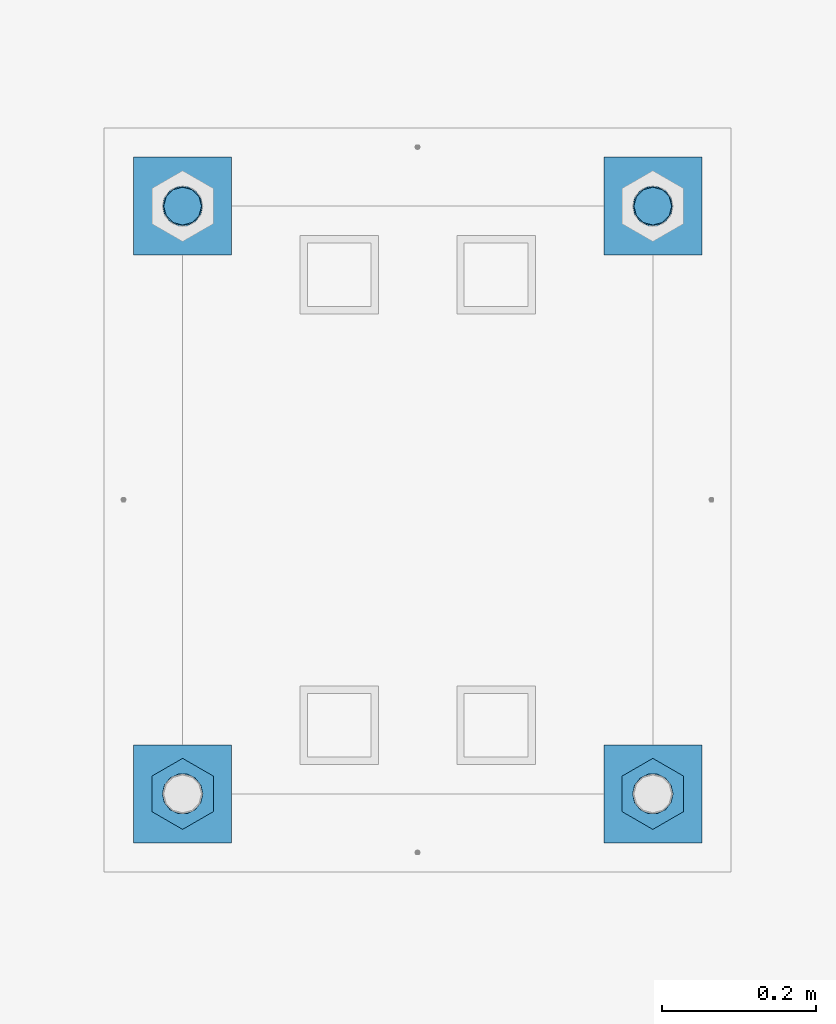
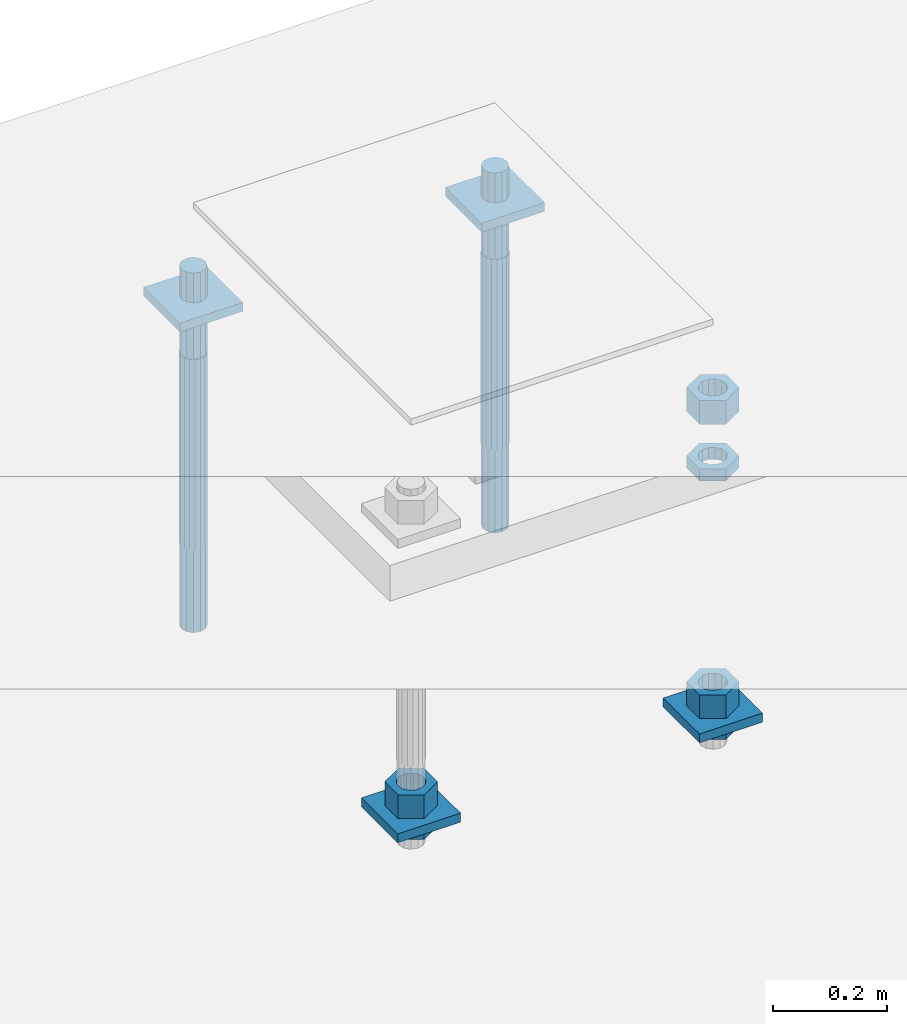
# One storey, part 2719 of 3843: 12 beams, 1 element without a shape of its own.
"""IFC2X3 building model written with IfcOpenShell, lengths in millimetres."""

from ifc_helpers import new_model, si_unit, frame, origin_with_axes, place, context, subcontext, project, spatial, faceted_brep, material, type_object, element, aggregate, save


model = new_model("IFC2X3")

# Units and contexts
model_context = context("Model", 3, precision=1e-05, world=origin_with_axes())
body_context = subcontext(model_context, "Body", "Model", "MODEL_VIEW")
ifc_project = project(units=[si_unit("LENGTHUNIT", "METRE", prefix="MILLI"), si_unit("AREAUNIT", "SQUARE_METRE"), si_unit("VOLUMEUNIT", "CUBIC_METRE"), si_unit("MASSUNIT", "GRAM", prefix="KILO"), si_unit("TIMEUNIT", "SECOND"), si_unit("PLANEANGLEUNIT", "RADIAN"), si_unit("SOLIDANGLEUNIT", "STERADIAN"), si_unit("THERMODYNAMICTEMPERATUREUNIT", "DEGREE_CELSIUS"), si_unit("LUMINOUSINTENSITYUNIT", "LUMEN")], contexts=[model_context])

# Site, building, storey
site_placement = place(None, origin_with_axes())
site = spatial("IfcSite", under=ifc_project, at=site_placement, CompositionType="ELEMENT")
building_placement = place(site_placement, origin_with_axes())
building = spatial("IfcBuilding", under=site, at=building_placement, Name="Undefined", CompositionType="ELEMENT")
storey_placement = place(building_placement, origin_with_axes())
storey = spatial("IfcBuildingStorey", under=building, at=storey_placement, Name="Undefined", CompositionType="ELEMENT", Elevation=0.0)

# Assembly, beams
assembly_placement = place(storey_placement, origin_with_axes())
assembly = element("IfcElementAssembly", 1, at=assembly_placement, inside=storey, Name="TEMPLATE", AssemblyPlace="NOTDEFINED", PredefinedType="RIGID_FRAME")
ifc_material_1 = material(Name="STEEL/A572-50")
beam_type_1 = type_object("IfcBeamType", PredefinedType="NOTDEFINED")
beam_1_placement = place(assembly_placement, frame((108585.000001526, 53086.0, 29873.575), z_axis=(0.0, -1.0, 0.0), x_axis=(1.0, 0.0, 0.0)))
beam_1 = element("IfcBeam", 2, at=beam_1_placement, type_object=beam_type_1, material=ifc_material_1, Name="WASHER_PLATE", context=body_context, shape_type="Brep", body=[
    faceted_brep([(0.0, 9.52500000000146, -63.5), (0.0, 9.52500000000146, 63.5), (127.0, 9.52500000000146, 63.5), (127.0, 9.52500000000146, -63.5), (0.0, -9.52500000000146, 63.5), (127.0, -9.52500000000146, 63.5), (0.0, -9.52500000000146, -63.5), (127.0, -9.52500000000146, -63.5)], [[[0, 1, 2, 3]], [[1, 4, 5, 2]], [[4, 6, 7, 5]], [[6, 0, 3, 7]], [[5, 7, 3, 2]], [[6, 4, 1, 0]]]),
])
beam_2_placement = place(assembly_placement, frame((109194.600001526, 53086.0, 29873.575), z_axis=(0.0, -1.0, 0.0), x_axis=(1.0, 0.0, 0.0)))
beam_2 = element("IfcBeam", 3, at=beam_2_placement, type_object=beam_type_1, material=ifc_material_1, Name="WASHER_PLATE", context=body_context, shape_type="Brep", body=[
    faceted_brep([(0.0, 9.52500000000146, -63.5), (0.0, 9.52500000000146, 63.5), (127.0, 9.52500000000146, 63.5), (127.0, 9.52500000000146, -63.5), (0.0, -9.52500000000146, 63.5), (127.0, -9.52500000000146, 63.5), (0.0, -9.52500000000146, -63.5), (127.0, -9.52500000000146, -63.5)], [[[0, 1, 2, 3]], [[1, 4, 5, 2]], [[4, 6, 7, 5]], [[6, 0, 3, 7]], [[5, 7, 3, 2]], [[6, 4, 1, 0]]]),
])
beam_3_placement = place(assembly_placement, frame((108585.000001526, 52324.0, 29244.925), z_axis=(0.0, -1.0, 0.0), x_axis=(1.0, 0.0, 0.0)))
beam_3 = element("IfcBeam", 4, at=beam_3_placement, type_object=beam_type_1, material=ifc_material_1, Name="WASHER_PLATE", context=body_context, shape_type="Brep", body=[
    faceted_brep([(0.0, 9.52500000000146, -63.5), (0.0, 9.52500000000146, 63.5), (127.0, 9.52500000000146, 63.5), (127.0, 9.52500000000146, -63.5), (0.0, -9.52500000000146, 63.5), (127.0, -9.52500000000146, 63.5), (0.0, -9.52500000000146, -63.5), (127.0, -9.52500000000146, -63.5)], [[[0, 1, 2, 3]], [[1, 4, 5, 2]], [[4, 6, 7, 5]], [[6, 0, 3, 7]], [[5, 7, 3, 2]], [[6, 4, 1, 0]]]),
])
beam_4_placement = place(assembly_placement, frame((109194.600001526, 52324.0, 29244.925), z_axis=(0.0, -1.0, 0.0), x_axis=(1.0, 0.0, 0.0)))
beam_4 = element("IfcBeam", 5, at=beam_4_placement, type_object=beam_type_1, material=ifc_material_1, Name="WASHER_PLATE", context=body_context, shape_type="Brep", body=[
    faceted_brep([(0.0, 9.52500000000146, -63.5), (0.0, 9.52500000000146, 63.5), (127.0, 9.52500000000146, 63.5), (127.0, 9.52500000000146, -63.5), (0.0, -9.52500000000146, 63.5), (127.0, -9.52500000000146, 63.5), (0.0, -9.52500000000146, -63.5), (127.0, -9.52500000000146, -63.5)], [[[0, 1, 2, 3]], [[1, 4, 5, 2]], [[4, 6, 7, 5]], [[6, 0, 3, 7]], [[5, 7, 3, 2]], [[6, 4, 1, 0]]]),
])
ifc_material_2 = material(Name="STEEL/A36")
beam_type_2 = type_object("IfcBeamType", Name="2_HALF_NUT", PredefinedType="NOTDEFINED")
beam_5_placement = place(assembly_placement, frame((108648.500001526, 52324.0, 29235.4), z_axis=(1.0, 0.0, 0.0), x_axis=(0.0, 0.0, -1.0)))
beam_5 = element("IfcBeam", 6, at=beam_5_placement, type_object=beam_type_2, material=ifc_material_2, Name="NUT", ObjectType="2_HALF_NUT", context=body_context, shape_type="Brep", body=[
    faceted_brep([(0.0, -46.0369987487793, 0.0), (0.0, -23.0184993743896, -39.869213104248), (25.4000000000015, -23.0184993743896, -39.869213104248), (25.4000000000015, -46.0369987487793, 0.0), (0.0, 23.0184993743896, -39.869213104248), (25.4000000000015, 23.0184993743896, -39.869213104248), (0.0, 46.0369987487793, 0.0), (25.4000000000015, 46.0369987487793, 0.0), (0.0, 23.0184993743896, 39.869213104248), (25.4000000000015, 23.0184993743896, 39.869213104248), (0.0, -23.0184993743896, 39.869213104248), (25.4000000000015, -23.0184993743896, 39.869213104248), (0.0, 0.0, 26.1940002441406), (0.0, 11.3650617044477, 23.5999013092805), (25.4000000000015, 11.3650617044477, 23.5999013092805), (25.4000000000015, 0.0, 26.1940002441406), (0.0, 20.4791109456419, 16.3316083006721), (25.4000000000015, 20.4791109456419, 16.3316083006721), (0.0, 25.5370200498292, 5.82867859874386), (25.4000000000015, 25.5370200498292, 5.82867859874386), (0.0, 25.5370200498292, -5.82867859874386), (25.4000000000015, 25.5370200498292, -5.82867859874386), (0.0, 20.4791109456419, -16.3316083006721), (25.4000000000015, 20.4791109456419, -16.3316083006721), (0.0, 11.3650617044477, -23.5999013092805), (25.4000000000015, 11.3650617044477, -23.5999013092805), (0.0, 0.0, -26.1940002441406), (25.4000000000015, 0.0, -26.1940002441406), (0.0, -11.3650617044477, -23.5999013092805), (25.4000000000015, -11.3650617044477, -23.5999013092805), (0.0, -20.4791109456419, -16.3316083006721), (25.4000000000015, -20.4791109456419, -16.3316083006721), (0.0, -25.5370200498292, -5.82867859874386), (25.4000000000015, -25.5370200498292, -5.82867859874386), (0.0, -25.5370200498292, 5.82867859874386), (25.4000000000015, -25.5370200498292, 5.82867859874386), (0.0, -20.4791109456419, 16.3316083006721), (25.4000000000015, -20.4791109456419, 16.3316083006721), (0.0, -11.3650617044477, 23.5999013092805), (25.4000000000015, -11.3650617044477, 23.5999013092805)], [[[0, 1, 2, 3]], [[1, 4, 5, 2]], [[4, 6, 7, 5]], [[6, 8, 9, 7]], [[8, 10, 11, 9]], [[10, 0, 3, 11]], [[12, 13, 14, 15]], [[13, 16, 17, 14]], [[16, 18, 19, 17]], [[18, 20, 21, 19]], [[20, 22, 23, 21]], [[22, 24, 25, 23]], [[24, 26, 27, 25]], [[26, 28, 29, 27]], [[28, 30, 31, 29]], [[30, 32, 33, 31]], [[32, 34, 35, 33]], [[34, 36, 37, 35]], [[36, 38, 39, 37]], [[38, 12, 15, 39]], [[5, 7, 9, 11, 3, 2], [17, 19, 21, 23, 25, 27, 29, 31, 33, 35, 37, 39, 15, 14]], [[10, 8, 6, 4, 1, 0], [38, 36, 34, 32, 30, 28, 26, 24, 22, 20, 18, 16, 13, 12]]]),
])
beam_6_placement = place(assembly_placement, frame((109258.100001526, 52324.0, 29787.85), z_axis=(1.0, 0.0, 0.0), x_axis=(0.0, 0.0, -1.0)))
beam_6 = element("IfcBeam", 7, at=beam_6_placement, type_object=beam_type_2, material=ifc_material_2, Name="NUT", ObjectType="2_HALF_NUT", context=body_context, shape_type="Brep", body=[
    faceted_brep([(0.0, -46.0369987487793, 0.0), (0.0, -23.0184993743896, -39.869213104248), (25.4000000000015, -23.0184993743896, -39.869213104248), (25.4000000000015, -46.0369987487793, 0.0), (0.0, 23.0184993743896, -39.869213104248), (25.4000000000015, 23.0184993743896, -39.869213104248), (0.0, 46.0369987487793, 0.0), (25.4000000000015, 46.0369987487793, 0.0), (0.0, 23.0184993743896, 39.869213104248), (25.4000000000015, 23.0184993743896, 39.869213104248), (0.0, -23.0184993743896, 39.869213104248), (25.4000000000015, -23.0184993743896, 39.869213104248), (0.0, 0.0, 26.1940002441406), (0.0, 11.3650617044477, 23.5999013092805), (25.4000000000015, 11.3650617044477, 23.5999013092805), (25.4000000000015, 0.0, 26.1940002441406), (0.0, 20.4791109456419, 16.3316083006721), (25.4000000000015, 20.4791109456419, 16.3316083006721), (0.0, 25.5370200498292, 5.82867859874386), (25.4000000000015, 25.5370200498292, 5.82867859874386), (0.0, 25.5370200498292, -5.82867859874386), (25.4000000000015, 25.5370200498292, -5.82867859874386), (0.0, 20.4791109456419, -16.3316083006721), (25.4000000000015, 20.4791109456419, -16.3316083006721), (0.0, 11.3650617044477, -23.5999013092805), (25.4000000000015, 11.3650617044477, -23.5999013092805), (0.0, 0.0, -26.1940002441406), (25.4000000000015, 0.0, -26.1940002441406), (0.0, -11.3650617044477, -23.5999013092805), (25.4000000000015, -11.3650617044477, -23.5999013092805), (0.0, -20.4791109456419, -16.3316083006721), (25.4000000000015, -20.4791109456419, -16.3316083006721), (0.0, -25.5370200498292, -5.82867859874386), (25.4000000000015, -25.5370200498292, -5.82867859874386), (0.0, -25.5370200498292, 5.82867859874386), (25.4000000000015, -25.5370200498292, 5.82867859874386), (0.0, -20.4791109456419, 16.3316083006721), (25.4000000000015, -20.4791109456419, 16.3316083006721), (0.0, -11.3650617044477, 23.5999013092805), (25.4000000000015, -11.3650617044477, 23.5999013092805)], [[[0, 1, 2, 3]], [[1, 4, 5, 2]], [[4, 6, 7, 5]], [[6, 8, 9, 7]], [[8, 10, 11, 9]], [[10, 0, 3, 11]], [[12, 13, 14, 15]], [[13, 16, 17, 14]], [[16, 18, 19, 17]], [[18, 20, 21, 19]], [[20, 22, 23, 21]], [[22, 24, 25, 23]], [[24, 26, 27, 25]], [[26, 28, 29, 27]], [[28, 30, 31, 29]], [[30, 32, 33, 31]], [[32, 34, 35, 33]], [[34, 36, 37, 35]], [[36, 38, 39, 37]], [[38, 12, 15, 39]], [[5, 7, 9, 11, 3, 2], [17, 19, 21, 23, 25, 27, 29, 31, 33, 35, 37, 39, 15, 14]], [[10, 8, 6, 4, 1, 0], [38, 36, 34, 32, 30, 28, 26, 24, 22, 20, 18, 16, 13, 12]]]),
])
beam_7_placement = place(assembly_placement, frame((109258.100001526, 52324.0, 29235.4), z_axis=(1.0, 0.0, 0.0), x_axis=(0.0, 0.0, -1.0)))
beam_7 = element("IfcBeam", 8, at=beam_7_placement, type_object=beam_type_2, material=ifc_material_2, Name="NUT", ObjectType="2_HALF_NUT", context=body_context, shape_type="Brep", body=[
    faceted_brep([(0.0, -46.0369987487793, 0.0), (0.0, -23.0184993743896, -39.869213104248), (25.4000000000015, -23.0184993743896, -39.869213104248), (25.4000000000015, -46.0369987487793, 0.0), (0.0, 23.0184993743896, -39.869213104248), (25.4000000000015, 23.0184993743896, -39.869213104248), (0.0, 46.0369987487793, 0.0), (25.4000000000015, 46.0369987487793, 0.0), (0.0, 23.0184993743896, 39.869213104248), (25.4000000000015, 23.0184993743896, 39.869213104248), (0.0, -23.0184993743896, 39.869213104248), (25.4000000000015, -23.0184993743896, 39.869213104248), (0.0, 0.0, 26.1940002441406), (0.0, 11.3650617044477, 23.5999013092805), (25.4000000000015, 11.3650617044477, 23.5999013092805), (25.4000000000015, 0.0, 26.1940002441406), (0.0, 20.4791109456419, 16.3316083006721), (25.4000000000015, 20.4791109456419, 16.3316083006721), (0.0, 25.5370200498292, 5.82867859874386), (25.4000000000015, 25.5370200498292, 5.82867859874386), (0.0, 25.5370200498292, -5.82867859874386), (25.4000000000015, 25.5370200498292, -5.82867859874386), (0.0, 20.4791109456419, -16.3316083006721), (25.4000000000015, 20.4791109456419, -16.3316083006721), (0.0, 11.3650617044477, -23.5999013092805), (25.4000000000015, 11.3650617044477, -23.5999013092805), (0.0, 0.0, -26.1940002441406), (25.4000000000015, 0.0, -26.1940002441406), (0.0, -11.3650617044477, -23.5999013092805), (25.4000000000015, -11.3650617044477, -23.5999013092805), (0.0, -20.4791109456419, -16.3316083006721), (25.4000000000015, -20.4791109456419, -16.3316083006721), (0.0, -25.5370200498292, -5.82867859874386), (25.4000000000015, -25.5370200498292, -5.82867859874386), (0.0, -25.5370200498292, 5.82867859874386), (25.4000000000015, -25.5370200498292, 5.82867859874386), (0.0, -20.4791109456419, 16.3316083006721), (25.4000000000015, -20.4791109456419, 16.3316083006721), (0.0, -11.3650617044477, 23.5999013092805), (25.4000000000015, -11.3650617044477, 23.5999013092805)], [[[0, 1, 2, 3]], [[1, 4, 5, 2]], [[4, 6, 7, 5]], [[6, 8, 9, 7]], [[8, 10, 11, 9]], [[10, 0, 3, 11]], [[12, 13, 14, 15]], [[13, 16, 17, 14]], [[16, 18, 19, 17]], [[18, 20, 21, 19]], [[20, 22, 23, 21]], [[22, 24, 25, 23]], [[24, 26, 27, 25]], [[26, 28, 29, 27]], [[28, 30, 31, 29]], [[30, 32, 33, 31]], [[32, 34, 35, 33]], [[34, 36, 37, 35]], [[36, 38, 39, 37]], [[38, 12, 15, 39]], [[5, 7, 9, 11, 3, 2], [17, 19, 21, 23, 25, 27, 29, 31, 33, 35, 37, 39, 15, 14]], [[10, 8, 6, 4, 1, 0], [38, 36, 34, 32, 30, 28, 26, 24, 22, 20, 18, 16, 13, 12]]]),
])
beam_type_3 = type_object("IfcBeamType", Name="2_HEAVY_HEX_NUT", PredefinedType="NOTDEFINED")
beam_8_placement = place(assembly_placement, frame((108648.500001526, 52324.0, 29305.25), z_axis=(1.0, 0.0, 0.0), x_axis=(0.0, 0.0, -1.0)))
beam_8 = element("IfcBeam", 9, at=beam_8_placement, type_object=beam_type_3, material=ifc_material_2, Name="NUT", ObjectType="2_HEAVY_HEX_NUT", context=body_context, shape_type="Brep", body=[
    faceted_brep([(0.0, -46.0369987487793, 0.0), (0.0, -23.0184993743896, -39.869213104248), (50.7999999999993, -23.0184993743896, -39.869213104248), (50.7999999999993, -46.0369987487793, 0.0), (0.0, 23.0184993743896, -39.869213104248), (50.7999999999993, 23.0184993743896, -39.869213104248), (0.0, 46.0369987487793, 0.0), (50.7999999999993, 46.0369987487793, 0.0), (0.0, 23.0184993743896, 39.869213104248), (50.7999999999993, 23.0184993743896, 39.869213104248), (0.0, -23.0184993743896, 39.869213104248), (50.7999999999993, -23.0184993743896, 39.869213104248), (0.0, 0.0, 26.1940002441406), (0.0, 11.3650617044477, 23.5999013092805), (50.7999999999993, 11.3650617044477, 23.5999013092805), (50.7999999999993, 0.0, 26.1940002441406), (0.0, 20.4791109456419, 16.3316083006721), (50.7999999999993, 20.4791109456419, 16.3316083006721), (0.0, 25.5370200498292, 5.82867859874386), (50.7999999999993, 25.5370200498292, 5.82867859874386), (0.0, 25.5370200498292, -5.82867859874386), (50.7999999999993, 25.5370200498292, -5.82867859874386), (0.0, 20.4791109456419, -16.3316083006721), (50.7999999999993, 20.4791109456419, -16.3316083006721), (0.0, 11.3650617044477, -23.5999013092805), (50.7999999999993, 11.3650617044477, -23.5999013092805), (0.0, 0.0, -26.1940002441406), (50.7999999999993, 0.0, -26.1940002441406), (0.0, -11.3650617044477, -23.5999013092805), (50.7999999999993, -11.3650617044477, -23.5999013092805), (0.0, -20.4791109456419, -16.3316083006721), (50.7999999999993, -20.4791109456419, -16.3316083006721), (0.0, -25.5370200498292, -5.82867859874386), (50.7999999999993, -25.5370200498292, -5.82867859874386), (0.0, -25.5370200498292, 5.82867859874386), (50.7999999999993, -25.5370200498292, 5.82867859874386), (0.0, -20.4791109456419, 16.3316083006721), (50.7999999999993, -20.4791109456419, 16.3316083006721), (0.0, -11.3650617044477, 23.5999013092805), (50.7999999999993, -11.3650617044477, 23.5999013092805)], [[[0, 1, 2, 3]], [[1, 4, 5, 2]], [[4, 6, 7, 5]], [[6, 8, 9, 7]], [[8, 10, 11, 9]], [[10, 0, 3, 11]], [[12, 13, 14, 15]], [[13, 16, 17, 14]], [[16, 18, 19, 17]], [[18, 20, 21, 19]], [[20, 22, 23, 21]], [[22, 24, 25, 23]], [[24, 26, 27, 25]], [[26, 28, 29, 27]], [[28, 30, 31, 29]], [[30, 32, 33, 31]], [[32, 34, 35, 33]], [[34, 36, 37, 35]], [[36, 38, 39, 37]], [[38, 12, 15, 39]], [[5, 7, 9, 11, 3, 2], [17, 19, 21, 23, 25, 27, 29, 31, 33, 35, 37, 39, 15, 14]], [[10, 8, 6, 4, 1, 0], [38, 36, 34, 32, 30, 28, 26, 24, 22, 20, 18, 16, 13, 12]]]),
])
beam_9_placement = place(assembly_placement, frame((109258.100001526, 52324.0, 29933.9), z_axis=(1.0, 0.0, 0.0), x_axis=(0.0, 0.0, -1.0)))
beam_9 = element("IfcBeam", 10, at=beam_9_placement, type_object=beam_type_3, material=ifc_material_2, Name="NUT", ObjectType="2_HEAVY_HEX_NUT", context=body_context, shape_type="Brep", body=[
    faceted_brep([(0.0, -46.0369987487793, 0.0), (0.0, -23.0184993743896, -39.869213104248), (50.7999999999993, -23.0184993743896, -39.869213104248), (50.7999999999993, -46.0369987487793, 0.0), (0.0, 23.0184993743896, -39.869213104248), (50.7999999999993, 23.0184993743896, -39.869213104248), (0.0, 46.0369987487793, 0.0), (50.7999999999993, 46.0369987487793, 0.0), (0.0, 23.0184993743896, 39.869213104248), (50.7999999999993, 23.0184993743896, 39.869213104248), (0.0, -23.0184993743896, 39.869213104248), (50.7999999999993, -23.0184993743896, 39.869213104248), (0.0, 0.0, 26.1940002441406), (0.0, 11.3650617044477, 23.5999013092805), (50.7999999999993, 11.3650617044477, 23.5999013092805), (50.7999999999993, 0.0, 26.1940002441406), (0.0, 20.4791109456419, 16.3316083006721), (50.7999999999993, 20.4791109456419, 16.3316083006721), (0.0, 25.5370200498292, 5.82867859874386), (50.7999999999993, 25.5370200498292, 5.82867859874386), (0.0, 25.5370200498292, -5.82867859874386), (50.7999999999993, 25.5370200498292, -5.82867859874386), (0.0, 20.4791109456419, -16.3316083006721), (50.7999999999993, 20.4791109456419, -16.3316083006721), (0.0, 11.3650617044477, -23.5999013092805), (50.7999999999993, 11.3650617044477, -23.5999013092805), (0.0, 0.0, -26.1940002441406), (50.7999999999993, 0.0, -26.1940002441406), (0.0, -11.3650617044477, -23.5999013092805), (50.7999999999993, -11.3650617044477, -23.5999013092805), (0.0, -20.4791109456419, -16.3316083006721), (50.7999999999993, -20.4791109456419, -16.3316083006721), (0.0, -25.5370200498292, -5.82867859874386), (50.7999999999993, -25.5370200498292, -5.82867859874386), (0.0, -25.5370200498292, 5.82867859874386), (50.7999999999993, -25.5370200498292, 5.82867859874386), (0.0, -20.4791109456419, 16.3316083006721), (50.7999999999993, -20.4791109456419, 16.3316083006721), (0.0, -11.3650617044477, 23.5999013092805), (50.7999999999993, -11.3650617044477, 23.5999013092805)], [[[0, 1, 2, 3]], [[1, 4, 5, 2]], [[4, 6, 7, 5]], [[6, 8, 9, 7]], [[8, 10, 11, 9]], [[10, 0, 3, 11]], [[12, 13, 14, 15]], [[13, 16, 17, 14]], [[16, 18, 19, 17]], [[18, 20, 21, 19]], [[20, 22, 23, 21]], [[22, 24, 25, 23]], [[24, 26, 27, 25]], [[26, 28, 29, 27]], [[28, 30, 31, 29]], [[30, 32, 33, 31]], [[32, 34, 35, 33]], [[34, 36, 37, 35]], [[36, 38, 39, 37]], [[38, 12, 15, 39]], [[5, 7, 9, 11, 3, 2], [17, 19, 21, 23, 25, 27, 29, 31, 33, 35, 37, 39, 15, 14]], [[10, 8, 6, 4, 1, 0], [38, 36, 34, 32, 30, 28, 26, 24, 22, 20, 18, 16, 13, 12]]]),
])
beam_10_placement = place(assembly_placement, frame((109258.100001526, 52324.0, 29305.25), z_axis=(1.0, 0.0, 0.0), x_axis=(0.0, 0.0, -1.0)))
beam_10 = element("IfcBeam", 11, at=beam_10_placement, type_object=beam_type_3, material=ifc_material_2, Name="NUT", ObjectType="2_HEAVY_HEX_NUT", context=body_context, shape_type="Brep", body=[
    faceted_brep([(0.0, -46.0369987487793, 0.0), (0.0, -23.0184993743896, -39.869213104248), (50.7999999999993, -23.0184993743896, -39.869213104248), (50.7999999999993, -46.0369987487793, 0.0), (0.0, 23.0184993743896, -39.869213104248), (50.7999999999993, 23.0184993743896, -39.869213104248), (0.0, 46.0369987487793, 0.0), (50.7999999999993, 46.0369987487793, 0.0), (0.0, 23.0184993743896, 39.869213104248), (50.7999999999993, 23.0184993743896, 39.869213104248), (0.0, -23.0184993743896, 39.869213104248), (50.7999999999993, -23.0184993743896, 39.869213104248), (0.0, 0.0, 26.1940002441406), (0.0, 11.3650617044477, 23.5999013092805), (50.7999999999993, 11.3650617044477, 23.5999013092805), (50.7999999999993, 0.0, 26.1940002441406), (0.0, 20.4791109456419, 16.3316083006721), (50.7999999999993, 20.4791109456419, 16.3316083006721), (0.0, 25.5370200498292, 5.82867859874386), (50.7999999999993, 25.5370200498292, 5.82867859874386), (0.0, 25.5370200498292, -5.82867859874386), (50.7999999999993, 25.5370200498292, -5.82867859874386), (0.0, 20.4791109456419, -16.3316083006721), (50.7999999999993, 20.4791109456419, -16.3316083006721), (0.0, 11.3650617044477, -23.5999013092805), (50.7999999999993, 11.3650617044477, -23.5999013092805), (0.0, 0.0, -26.1940002441406), (50.7999999999993, 0.0, -26.1940002441406), (0.0, -11.3650617044477, -23.5999013092805), (50.7999999999993, -11.3650617044477, -23.5999013092805), (0.0, -20.4791109456419, -16.3316083006721), (50.7999999999993, -20.4791109456419, -16.3316083006721), (0.0, -25.5370200498292, -5.82867859874386), (50.7999999999993, -25.5370200498292, -5.82867859874386), (0.0, -25.5370200498292, 5.82867859874386), (50.7999999999993, -25.5370200498292, 5.82867859874386), (0.0, -20.4791109456419, 16.3316083006721), (50.7999999999993, -20.4791109456419, 16.3316083006721), (0.0, -11.3650617044477, 23.5999013092805), (50.7999999999993, -11.3650617044477, 23.5999013092805)], [[[0, 1, 2, 3]], [[1, 4, 5, 2]], [[4, 6, 7, 5]], [[6, 8, 9, 7]], [[8, 10, 11, 9]], [[10, 0, 3, 11]], [[12, 13, 14, 15]], [[13, 16, 17, 14]], [[16, 18, 19, 17]], [[18, 20, 21, 19]], [[20, 22, 23, 21]], [[22, 24, 25, 23]], [[24, 26, 27, 25]], [[26, 28, 29, 27]], [[28, 30, 31, 29]], [[30, 32, 33, 31]], [[32, 34, 35, 33]], [[34, 36, 37, 35]], [[36, 38, 39, 37]], [[38, 12, 15, 39]], [[5, 7, 9, 11, 3, 2], [17, 19, 21, 23, 25, 27, 29, 31, 33, 35, 37, 39, 15, 14]], [[10, 8, 6, 4, 1, 0], [38, 36, 34, 32, 30, 28, 26, 24, 22, 20, 18, 16, 13, 12]]]),
])
ifc_material_3 = material()
beam_type_4 = type_object("IfcBeamType", PredefinedType="NOTDEFINED")
beam_11_placement = place(assembly_placement, frame((109258.1, 53085.9999984741, 29762.45), z_axis=(0.0, -1.0, 0.0), x_axis=(0.0, 0.0, -1.0)))
beam_11 = element("IfcBeam", 12, at=beam_11_placement, type_object=beam_type_4, material=ifc_material_3, Name="ANCHOR_ROD", context=body_context, shape_type="Brep", body=[
    faceted_brep([(0.0, -23.4665401257807, -9.72015918207035), (0.0, -17.9605122421344, -17.9605122421417), (406.399999999998, -17.9605122421344, -17.9605122421417), (406.399999999998, -23.4665401257807, -9.72015918207035), (0.0, -9.72015918207762, -23.466540125788), (406.399999999998, -9.72015918207762, -23.466540125788), (0.0, 0.0, -25.4000000000015), (406.399999999998, 0.0, -25.4000000000015), (0.0, 9.72015918207762, -23.466540125788), (406.399999999998, 9.72015918207762, -23.466540125788), (0.0, 17.9605122421344, -17.9605122421417), (406.399999999998, 17.9605122421344, -17.9605122421417), (0.0, 23.4665401257807, -9.72015918207035), (406.399999999998, 23.4665401257807, -9.72015918207035), (0.0, 25.3999996185303, 0.0), (406.399999999998, 25.3999999999942, 0.0), (0.0, 23.4665401257807, 9.72015918207035), (406.399999999998, 23.4665401257807, 9.72015918207035), (0.0, 17.9605122421344, 17.9605122421417), (406.399999999998, 17.9605122421344, 17.9605122421417), (0.0, 9.72015918207762, 23.466540125788), (406.399999999998, 9.72015918207762, 23.466540125788), (0.0, 0.0, 25.4000000000015), (406.399999999998, 0.0, 25.4000000000015), (0.0, -9.72015918207762, 23.466540125788), (406.399999999998, -9.72015918207762, 23.466540125788), (0.0, -17.9605122421344, 17.9605122421417), (406.399999999998, -17.9605122421344, 17.9605122421417), (0.0, -23.4665401257807, 9.72015918207035), (406.399999999998, -23.4665401257807, 9.72015918207035), (0.0, -25.3999996185303, 0.0), (406.399999999998, -25.3999999999942, 0.0), (584.200000000001, -12.2499999999854, -21.2176223927163), (584.200000000001, 1.45519152283669e-11, -24.5), (584.200000000001, 12.2500000000146, -21.2176223927163), (584.200000000001, 21.2176223927381, -12.25), (584.200000000001, 24.5000000000146, 0.0), (584.200000000001, 21.2176223927381, 12.25), (584.200000000001, 12.2500000000146, 21.2176223927163), (584.200000000001, 1.45519152283669e-11, 24.5), (584.200000000001, -12.2499999999854, 21.2176223927163), (584.200000000001, -21.217622392709, 12.25), (584.200000000001, -24.4999999999854, 0.0), (584.200000000001, -21.217622392709, -12.25), (406.399999999998, -24.4999999999854, 0.0), (406.399999999998, -21.217622392709, -12.25), (406.399999999998, -12.2499999999854, -21.2176223927163), (406.399999999998, 1.45519152283669e-11, -24.5), (406.399999999998, 12.2500000000146, -21.2176223927163), (406.399999999998, 21.2176223927381, -12.25), (406.399999999998, 24.5000000000146, 0.0), (406.399999999998, 21.2176223927381, 12.25), (406.399999999998, 12.2500000000146, 21.2176223927163), (406.399999999998, 1.45519152283669e-11, 24.5), (406.399999999998, -12.2499999999854, 21.2176223927163), (406.399999999998, -21.217622392709, 12.25), (0.0, 12.2500000000146, 21.2176223927163), (0.0, 1.45519152283669e-11, 24.5), (0.0, -12.2499999999854, 21.2176223927163), (0.0, -21.217622392709, 12.25), (0.0, -24.4999999999854, 0.0), (0.0, -21.217622392709, -12.25), (0.0, -12.2499999999854, -21.2176223927163), (0.0, 1.45519152283669e-11, -24.5), (0.0, 12.2500000000146, -21.2176223927163), (0.0, 21.2176223927381, -12.25), (0.0, 24.5000000000146, 0.0), (0.0, 21.2176223927381, 12.25), (-184.150000000001, -21.217622392709, 12.25), (-184.150000000001, -12.2499999999854, 21.2176223927163), (-184.150000000001, 1.45519152283669e-11, 24.5), (-184.150000000001, 12.2500000000146, 21.2176223927163), (-184.150000000001, 21.2176223927381, 12.25), (-184.150000000001, 24.5000000000146, 0.0), (-184.150000000001, 21.2176223927381, -12.25), (-184.150000000001, 12.2500000000146, -21.2176223927163), (-184.150000000001, 1.45519152283669e-11, -24.5), (-184.150000000001, -12.2499999999854, -21.2176223927163), (-184.150000000001, -21.217622392709, -12.25), (-184.150000000001, -24.4999999999854, 0.0)], [[[0, 1, 2, 3]], [[1, 4, 5, 2]], [[4, 6, 7, 5]], [[6, 8, 9, 7]], [[8, 10, 11, 9]], [[10, 12, 13, 11]], [[12, 14, 15, 13]], [[14, 16, 17, 15]], [[16, 18, 19, 17]], [[18, 20, 21, 19]], [[20, 22, 23, 21]], [[22, 24, 25, 23]], [[24, 26, 27, 25]], [[26, 28, 29, 27]], [[28, 30, 31, 29]], [[32, 33, 34, 35, 36, 37, 38, 39, 40, 41, 42, 43]], [[43, 42, 44, 45]], [[32, 43, 45, 46]], [[33, 32, 46, 47]], [[34, 33, 47, 48]], [[35, 34, 48, 49]], [[36, 35, 49, 50]], [[37, 36, 50, 51]], [[38, 37, 51, 52]], [[39, 38, 52, 53]], [[40, 39, 53, 54]], [[41, 40, 54, 55]], [[42, 41, 55, 44]], [[2, 5, 7, 9, 11, 13, 15, 17, 19, 21, 23, 25, 27, 29, 31, 3], [54, 53, 52, 51, 50, 49, 48, 47, 46, 45, 44, 55]], [[30, 0, 3, 31]], [[28, 26, 24, 22, 20, 18, 16, 14, 12, 10, 8, 6, 4, 1, 0, 30], [56, 57, 58, 59, 60, 61, 62, 63, 64, 65, 66, 67]], [[68, 69, 70, 71, 72, 73, 74, 75, 76, 77, 78, 79]], [[71, 70, 57, 56]], [[72, 71, 56, 67]], [[73, 72, 67, 66]], [[74, 73, 66, 65]], [[75, 74, 65, 64]], [[76, 75, 64, 63]], [[77, 76, 63, 62]], [[78, 77, 62, 61]], [[79, 78, 61, 60]], [[68, 79, 60, 59]], [[69, 68, 59, 58]], [[70, 69, 58, 57]]]),
])
beam_12_placement = place(assembly_placement, frame((108648.5, 53085.9999984741, 29762.45), z_axis=(0.0, -1.0, 0.0), x_axis=(0.0, 0.0, -1.0)))
beam_12 = element("IfcBeam", 13, at=beam_12_placement, type_object=beam_type_4, material=ifc_material_3, Name="ANCHOR_ROD", context=body_context, shape_type="Brep", body=[
    faceted_brep([(0.0, -23.4665401257807, -9.72015918207035), (0.0, -17.9605122421344, -17.9605122421417), (406.399999999998, -17.9605122421344, -17.9605122421417), (406.399999999998, -23.4665401257807, -9.72015918207035), (0.0, -9.72015918207762, -23.466540125788), (406.399999999998, -9.72015918207762, -23.466540125788), (0.0, 0.0, -25.4000000000015), (406.399999999998, 0.0, -25.4000000000015), (0.0, 9.72015918207762, -23.466540125788), (406.399999999998, 9.72015918207762, -23.466540125788), (0.0, 17.9605122421344, -17.9605122421417), (406.399999999998, 17.9605122421344, -17.9605122421417), (0.0, 23.4665401257807, -9.72015918207035), (406.399999999998, 23.4665401257807, -9.72015918207035), (0.0, 25.3999996185303, 0.0), (406.399999999998, 25.3999999999942, 0.0), (0.0, 23.4665401257807, 9.72015918207035), (406.399999999998, 23.4665401257807, 9.72015918207035), (0.0, 17.9605122421344, 17.9605122421417), (406.399999999998, 17.9605122421344, 17.9605122421417), (0.0, 9.72015918207762, 23.466540125788), (406.399999999998, 9.72015918207762, 23.466540125788), (0.0, 0.0, 25.4000000000015), (406.399999999998, 0.0, 25.4000000000015), (0.0, -9.72015918207762, 23.466540125788), (406.399999999998, -9.72015918207762, 23.466540125788), (0.0, -17.9605122421344, 17.9605122421417), (406.399999999998, -17.9605122421344, 17.9605122421417), (0.0, -23.4665401257807, 9.72015918207035), (406.399999999998, -23.4665401257807, 9.72015918207035), (0.0, -25.3999996185303, 0.0), (406.399999999998, -25.3999999999942, 0.0), (584.200000000001, -12.2499999999854, -21.2176223927163), (584.200000000001, 1.45519152283669e-11, -24.5), (584.200000000001, 12.2500000000146, -21.2176223927163), (584.200000000001, 21.2176223927381, -12.25), (584.200000000001, 24.5000000000146, 0.0), (584.200000000001, 21.2176223927381, 12.25), (584.200000000001, 12.2500000000146, 21.2176223927163), (584.200000000001, 1.45519152283669e-11, 24.5), (584.200000000001, -12.2499999999854, 21.2176223927163), (584.200000000001, -21.217622392709, 12.25), (584.200000000001, -24.4999999999854, 0.0), (584.200000000001, -21.217622392709, -12.25), (406.399999999998, -24.4999999999854, 0.0), (406.399999999998, -21.217622392709, -12.25), (406.399999999998, -12.2499999999854, -21.2176223927163), (406.399999999998, 1.45519152283669e-11, -24.5), (406.399999999998, 12.2500000000146, -21.2176223927163), (406.399999999998, 21.2176223927381, -12.25), (406.399999999998, 24.5000000000146, 0.0), (406.399999999998, 21.2176223927381, 12.25), (406.399999999998, 12.2500000000146, 21.2176223927163), (406.399999999998, 1.45519152283669e-11, 24.5), (406.399999999998, -12.2499999999854, 21.2176223927163), (406.399999999998, -21.217622392709, 12.25), (0.0, 12.2500000000146, 21.2176223927163), (0.0, 1.45519152283669e-11, 24.5), (0.0, -12.2499999999854, 21.2176223927163), (0.0, -21.217622392709, 12.25), (0.0, -24.4999999999854, 0.0), (0.0, -21.217622392709, -12.25), (0.0, -12.2499999999854, -21.2176223927163), (0.0, 1.45519152283669e-11, -24.5), (0.0, 12.2500000000146, -21.2176223927163), (0.0, 21.2176223927381, -12.25), (0.0, 24.5000000000146, 0.0), (0.0, 21.2176223927381, 12.25), (-184.150000000001, -21.217622392709, 12.25), (-184.150000000001, -12.2499999999854, 21.2176223927163), (-184.150000000001, 1.45519152283669e-11, 24.5), (-184.150000000001, 12.2500000000146, 21.2176223927163), (-184.150000000001, 21.2176223927381, 12.25), (-184.150000000001, 24.5000000000146, 0.0), (-184.150000000001, 21.2176223927381, -12.25), (-184.150000000001, 12.2500000000146, -21.2176223927163), (-184.150000000001, 1.45519152283669e-11, -24.5), (-184.150000000001, -12.2499999999854, -21.2176223927163), (-184.150000000001, -21.217622392709, -12.25), (-184.150000000001, -24.4999999999854, 0.0)], [[[0, 1, 2, 3]], [[1, 4, 5, 2]], [[4, 6, 7, 5]], [[6, 8, 9, 7]], [[8, 10, 11, 9]], [[10, 12, 13, 11]], [[12, 14, 15, 13]], [[14, 16, 17, 15]], [[16, 18, 19, 17]], [[18, 20, 21, 19]], [[20, 22, 23, 21]], [[22, 24, 25, 23]], [[24, 26, 27, 25]], [[26, 28, 29, 27]], [[28, 30, 31, 29]], [[32, 33, 34, 35, 36, 37, 38, 39, 40, 41, 42, 43]], [[43, 42, 44, 45]], [[32, 43, 45, 46]], [[33, 32, 46, 47]], [[34, 33, 47, 48]], [[35, 34, 48, 49]], [[36, 35, 49, 50]], [[37, 36, 50, 51]], [[38, 37, 51, 52]], [[39, 38, 52, 53]], [[40, 39, 53, 54]], [[41, 40, 54, 55]], [[42, 41, 55, 44]], [[2, 5, 7, 9, 11, 13, 15, 17, 19, 21, 23, 25, 27, 29, 31, 3], [54, 53, 52, 51, 50, 49, 48, 47, 46, 45, 44, 55]], [[30, 0, 3, 31]], [[28, 26, 24, 22, 20, 18, 16, 14, 12, 10, 8, 6, 4, 1, 0, 30], [56, 57, 58, 59, 60, 61, 62, 63, 64, 65, 66, 67]], [[68, 69, 70, 71, 72, 73, 74, 75, 76, 77, 78, 79]], [[71, 70, 57, 56]], [[72, 71, 56, 67]], [[73, 72, 67, 66]], [[74, 73, 66, 65]], [[75, 74, 65, 64]], [[76, 75, 64, 63]], [[77, 76, 63, 62]], [[78, 77, 62, 61]], [[79, 78, 61, 60]], [[68, 79, 60, 59]], [[69, 68, 59, 58]], [[70, 69, 58, 57]]]),
])
aggregate(assembly, [beam_11, beam_12, beam_1, beam_2, beam_8, beam_5, beam_3, beam_6, beam_9, beam_10, beam_7, beam_4])

save(model, "model.ifc")
